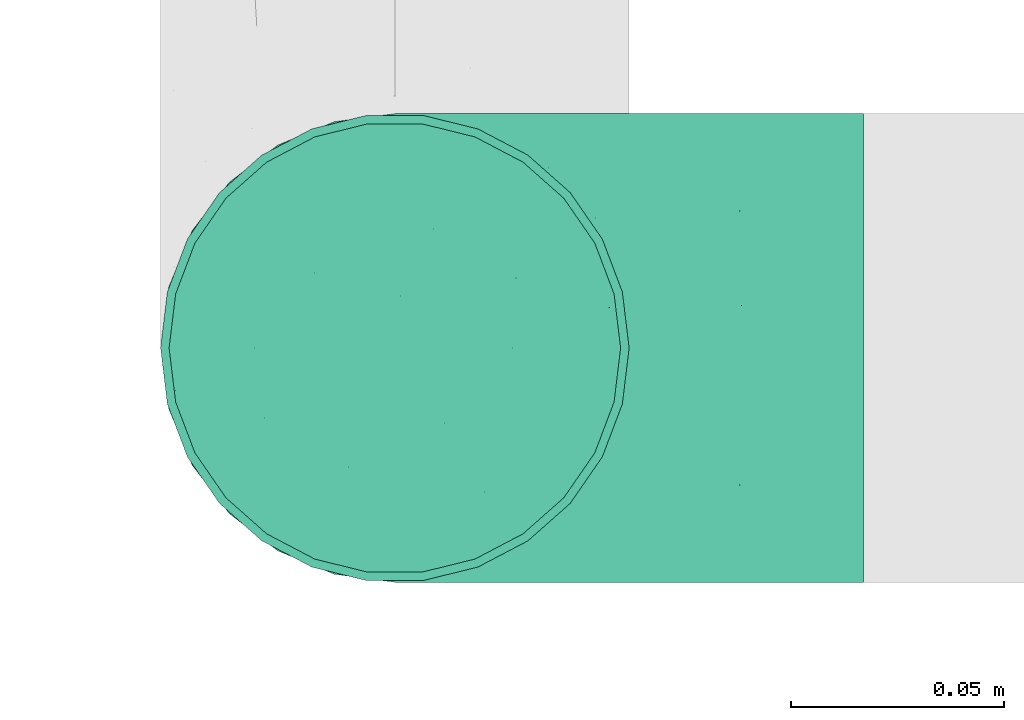
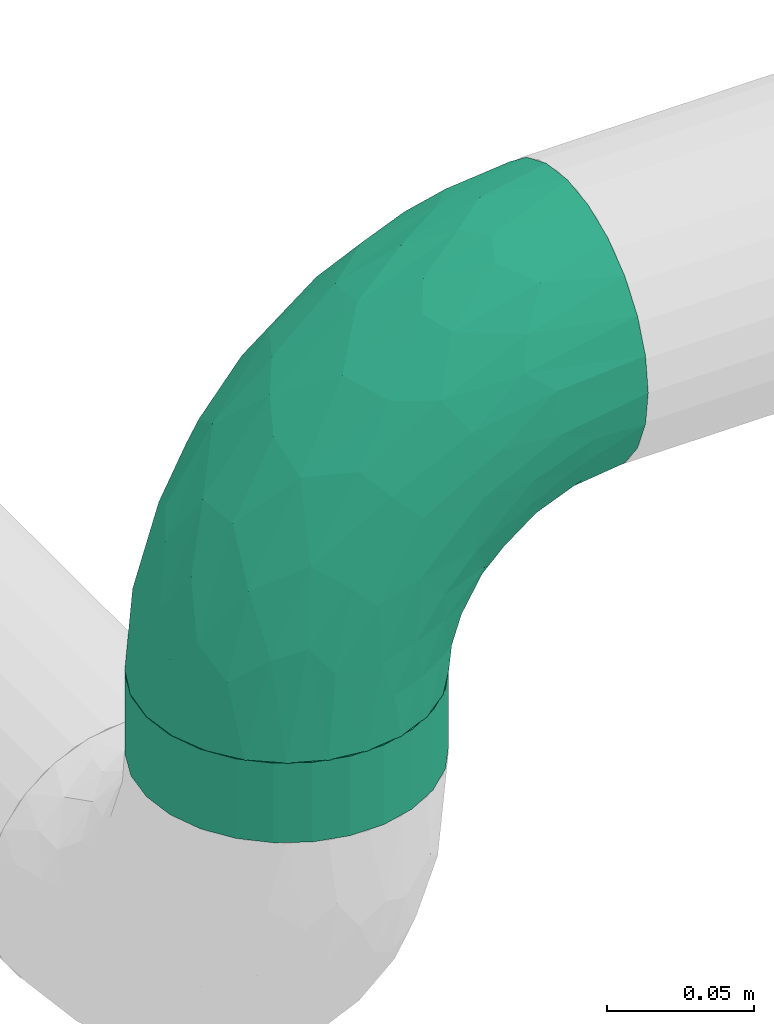
# One storey, part 37 of 91: 1 flow fitting, 1 flow segment.
"""IFC2X3 building model written with IfcOpenShell, lengths in millimetres."""

from ifc_helpers import new_model, entity, si_unit, converted_unit, derived_unit, direction, frame, origin_with_axes, origin_2d_with_axis, place, context, subcontext, project, spatial, hollow_circle, extrude, open_shell, surface_model, source, transform, mapped, material, layer, layer_set, layer_usage, type_object, element, save


model = new_model("IFC2X3")

# Units and contexts
model_context = context("Model", 3, precision=1e-05, world=origin_with_axes(), true_north=direction((0.0, 1.0)))
body_context = subcontext(model_context, "Body", "Model", "MODEL_VIEW")
ifc_project = project(units=[si_unit("AREAUNIT", "SQUARE_METRE"), si_unit("VOLUMEUNIT", "CUBIC_METRE", prefix="DECI"), si_unit("TIMEUNIT", "SECOND"), si_unit("THERMODYNAMICTEMPERATUREUNIT", "DEGREE_CELSIUS"), si_unit("PRESSUREUNIT", "PASCAL"), si_unit("MASSUNIT", "GRAM", prefix="KILO"), si_unit("LENGTHUNIT", "METRE", prefix="MILLI"), si_unit("POWERUNIT", "WATT"), si_unit("ELECTRICCURRENTUNIT", "AMPERE"), si_unit("ELECTRICVOLTAGEUNIT", "VOLT"), derived_unit("VOLUMETRICFLOWRATEUNIT", [(si_unit("VOLUMEUNIT", "CUBIC_METRE", prefix="DECI"), 1), (si_unit("TIMEUNIT", "SECOND"), -1)]), derived_unit("LINEARVELOCITYUNIT", [(si_unit("LENGTHUNIT", "METRE"), 1), (si_unit("TIMEUNIT", "SECOND"), -1)]), derived_unit("MASSDENSITYUNIT", [(si_unit("MASSUNIT", "GRAM", prefix="KILO"), 1), (si_unit("VOLUMEUNIT", "CUBIC_METRE"), -1)]), converted_unit("PLANEANGLEUNIT", "DEGREE", entity("IfcRatioMeasure", 0.01745), si_unit("PLANEANGLEUNIT", "RADIAN"), dimensions=[0, 0, 0, 0, 0, 0, 0])], contexts=[model_context])

# Site, building, storey
site_placement = place(None, origin_with_axes())
site = spatial("IfcSite", under=ifc_project, at=site_placement, CompositionType="ELEMENT")
building_placement = place(site_placement, origin_with_axes())
building = spatial("IfcBuilding", under=site, at=building_placement, Name="mc-building", CompositionType="ELEMENT")
storey_placement = place(building_placement, frame((0.0, 0.0, 8700.0), z_axis=(0.0, 0.0, 1.0), x_axis=(1.0, 0.0, 0.0)))
storey = spatial("IfcBuildingStorey", under=building, at=storey_placement, CompositionType="ELEMENT", Elevation=8700.0)

# Flow segment
ifc_material = material(Name="FZ1")
ifc_layer = layer(ifc_material, 0.0)
ifc_layer_set = layer_set([ifc_layer], Name="FZ1")
ifc_layer_usage = layer_usage(ifc_layer_set, "AXIS1", "POSITIVE", 0.0)
duct_segment_type = type_object("IfcDuctSegmentType", PredefinedType="RIGIDSEGMENT")
shared_shape_1 = source(origin_with_axes(), body_context, "Body", "SweptSolid", [
    extrude(hollow_circle(Radius=55.0, WallThickness=2.0, at=origin_2d_with_axis()), frame((0.0, 0.0, 0.0), z_axis=(1.0, 0.0, 0.0), x_axis=(0.0, 1.0, 0.0)), (0.0, 0.0, 1.0), 33.0),
])
flow_segment_placement = place(storey_placement, frame((5487.14677, 10175.43966, 558.0), z_axis=(0.0, 1.0, 0.0), x_axis=(0.0, 0.0, -1.0)))
element("IfcFlowSegment", 1, at=flow_segment_placement, inside=storey, type_object=duct_segment_type, material=ifc_layer_usage, context=body_context, shape_type="MappedRepresentation", body=[
    mapped(shared_shape_1, transform((0.0, 0.0, 0.0), scale=1.0)),
])

# Flow fitting
duct_fitting_type = type_object("IfcDuctFittingType", Name="BU", PredefinedType="BEND")
shared_shape_2 = source(origin_with_axes(), body_context, "Body", "SurfaceModel", [
    surface_model("IfcShellBasedSurfaceModel", [(-110.0, 0.0, -55.0), (-110.0, -14.23505, -53.12592), (-110.0, 14.23505, -53.12592), (-110.0, 53.12592, 14.23505), (-110.0, 27.5, -47.63139), (-110.0, 38.89087, -38.89087), (-110.0, -55.0, 0.0), (-110.0, -53.12592, 14.23505), (-110.0, -38.89087, -38.89087), (-110.0, -27.5, -47.63139), (-110.0, -53.12592, -14.23505), (-110.0, -47.63139, -27.5), (-110.0, -14.23505, 53.12592), (-110.0, 14.23505, 53.12592), (-110.0, 27.5, 47.63139), (-110.0, -47.63139, 27.5), (-110.0, -38.89087, 38.89087), (-110.0, -27.5, 47.63139), (-110.0, 0.0, 55.0), (-110.0, 55.0, 0.0), (-110.0, 53.12592, -14.23505), (-110.0, 47.63139, -27.5), (-110.0, 47.63139, 27.5), (-110.0, 38.89087, 38.89087), (-14.23505, 110.0, -53.12592), (-55.0, 110.0, 0.0), (0.0, 110.0, -55.0), (-27.5, 110.0, -47.63139), (-38.89087, 110.0, -38.89087), (-47.63139, 110.0, -27.5), (38.89087, 110.0, -38.89087), (53.12592, 110.0, 14.23505), (27.5, 110.0, -47.63139), (14.23505, 110.0, -53.12592), (47.63139, 110.0, -27.5), (53.12592, 110.0, -14.23505), (55.0, 110.0, 0.0), (-53.12592, 110.0, -14.23505), (-53.12592, 110.0, 14.23505), (-47.63139, 110.0, 27.5), (-38.89087, 110.0, 38.89087), (-27.5, 110.0, 47.63139), (0.0, 110.0, 55.0), (-14.23505, 110.0, 53.12592), (38.89087, 110.0, 38.89087), (47.63139, 110.0, 27.5), (27.5, 110.0, 47.63139), (14.23505, 110.0, 53.12592), (-64.21732, 48.68956, 43.63444), (-76.6405, 38.18013, 45.55988), (-60.44912, 32.56953, 51.94617), (-76.00813, 5.38378, 55.0), (-90.15553, 11.94394, 54.09138), (-78.5998, 26.77405, 50.81338), (-70.18771, 18.55163, 54.03432), (-75.55424, 54.2118, 32.41257), (-93.27622, 45.77614, 33.48188), (-96.12334, 22.13664, 50.81337), (-21.00813, 45.34362, 55.0), (-18.36258, 70.48427, 54.04484), (-32.04182, 59.64019, 52.24446), (-63.88653, 74.77858, 17.99134), (-74.66383, 63.08407, 19.92123), (-63.60674, 66.07878, 29.97482), (-99.597, 52.72185, 18.52927), (-93.11138, 56.59448, 10.50359), (-98.21577, 57.34403, 0.0), (-53.42855, 92.60092, 21.04759), (-88.54852, 54.8376, 21.04759), (-11.86161, 90.23965, 54.10313), (-5.38378, 76.00813, 55.0), (-57.34403, 98.21577, 0.0), (-56.64619, 93.12774, 10.22088), (-45.34362, 21.00813, 55.0), (-44.60838, 44.60838, 52.13415), (-92.68484, 35.46673, 43.63443), (-22.25266, 95.40765, 50.81337), (-35.97783, 90.61597, 43.63443), (-43.70931, 69.58671, 44.47149), (-27.23711, 77.39884, 50.81337), (-57.2828, 79.3123, 24.9774), (-58.67786, 84.31125, 16.04456), (-82.93277, 60.36161, 12.91784), (-49.88337, 54.51816, 47.224), (-74.57753, 66.83759, 9.55742), (-45.35812, 94.97281, 33.48188), (-59.18663, 88.95241, 0.0), (-51.517, 78.6292, 33.48188), (-65.14788, 80.03077, 0.0), (-56.45322, 62.06476, 39.63545), (-88.95241, 59.18663, 0.0), (-71.10913, 71.10913, 0.0), (-80.03077, 65.14788, 0.0), (-94.9309, 45.36788, -33.48188), (-93.11358, 56.60141, -10.46614), (-99.64997, 52.79499, -18.30015), (-90.20425, 36.08686, -43.63443), (-79.99933, 46.56772, -37.92748), (-76.00813, 5.38378, -55.0), (-72.75364, 19.68651, -53.60527), (-45.34362, 21.00813, -55.0), (-21.91957, 65.12078, -53.85897), (-5.38378, 76.00813, -55.0), (-21.00813, 45.34362, -55.0), (-35.41876, 92.89265, -43.63443), (-91.10309, 11.02766, -54.21832), (-45.77614, 93.27622, -33.48188), (-90.50474, 23.21022, -50.81337), (-70.92854, 33.31794, -49.51754), (-78.52933, 63.35627, -11.73997), (-24.91508, 84.05606, -50.81337), (-88.78941, 54.74452, -21.04759), (-69.59921, 57.34866, -33.48187), (-73.36422, 62.46673, -22.94182), (-63.49062, 67.59111, -28.46929), (-56.59448, 93.11138, -10.50359), (-54.8376, 88.54852, -21.04759), (-54.10679, 75.85581, -32.31867), (-57.75956, 31.09612, -52.80882), (-52.72185, 99.597, -18.52927), (-12.62913, 89.46304, -53.99097), (-34.46825, 66.46123, -50.04329), (-43.9837, 43.9837, -52.42279), (-65.78527, 72.58348, -17.68796), (-70.34468, 43.65295, -44.21951), (-57.47001, 51.99467, -44.91465), (-60.72547, 82.29174, -12.88567), (-42.34915, 74.24548, -43.63444), (-57.25194, 63.5016, -38.08211), (-80.95344, 53.56991, -29.32027), (-52.32891, 4.55257, -54.0482), (32.52942, 47.13398, -30.48571), (14.88266, 20.92917, -33.7947), (14.95561, 36.05775, -42.26543), (30.24048, 70.09027, -41.7461), (19.3559, 65.35825, -48.00507), (-70.35075, -46.44478, -19.5952), (-47.13398, -32.52942, -30.48571), (-28.49299, -30.5778, -16.4009), (-4.55257, 52.32891, -54.0482), (-22.4954, 22.4954, -53.25347), (-75.47368, -11.22546, -52.60718), (-81.32209, -51.5606, -9.98467), (-80.81763, -41.84862, -32.14655), (-70.09027, -30.24048, -41.7461), (-36.05774, -14.95561, -42.26543), (-9.15831, -10.852, -27.8997), (-65.35825, -19.3559, -48.00507), (11.22546, 75.47368, -52.60718), (3.94376, 43.9333, -50.53315), (-13.39742, 13.39743, -48.13058), (-43.9333, -3.94376, -50.53315), (49.37776, 67.29486, 0.0), (41.8609, 47.82256, -9.92641), (50.20582, 74.51695, -9.9731), (18.93131, 11.7156, -17.56239), (-27.5, -32.89419, 0.0), (-1.23348, -12.25375, -12.18106), (41.84862, 80.81763, -32.14655), (35.70604, 41.31408, -20.38235), (46.44478, 70.35075, -19.5952), (32.89419, 27.5, 0.0), (6.67262, -6.67262, 0.0), (-67.29486, -49.37776, 0.0), (-50.36265, -42.95545, -9.51562), (-5.47251, 5.47251, -39.92906), (-70.35075, -46.44478, 19.5952), (-74.51695, -50.20582, 9.9731), (-41.31407, -35.70604, 20.38235), (-47.13398, -32.52942, 30.48571), (-80.81763, -41.84862, 32.14655), (-4.55257, 52.32891, 54.0482), (11.22546, 75.47368, 52.60718), (-43.9333, -3.94376, 50.53315), (-65.35825, -19.3559, 48.00507), (-36.05774, -14.95561, 42.26543), (-70.09027, -30.24048, 41.7461), (-11.7156, -18.93131, 17.56239), (30.5778, 28.49299, 16.4009), (12.25375, 1.23348, 12.18106), (51.5606, 81.32209, 9.98467), (42.95545, 50.36265, 9.51562), (-75.47368, -11.22546, 52.60718), (-52.32891, 4.55257, 54.0482), (3.94376, 43.9333, 50.53315), (-22.4954, 22.4954, 53.25347), (-13.39742, 13.39743, 48.13058), (10.852, 9.15831, 27.8997), (-20.92916, -14.88266, 33.79469), (-47.82256, -41.8609, 9.92641), (32.52942, 47.13398, 30.48571), (46.44478, 70.35075, 19.5952), (41.84862, 80.81763, 32.14655), (30.24048, 70.09027, 41.7461), (19.3559, 65.35825, 48.00507), (14.95561, 36.05775, 42.26543), (-5.47251, 5.47251, 39.92906)], [open_shell([[[0, 1, 2]], [[2, 3, 4]], [[4, 3, 5]], [[2, 6, 7]], [[8, 6, 9]], [[1, 9, 6]], [[10, 6, 11]], [[8, 11, 6]], [[6, 2, 1]], [[12, 13, 14]], [[15, 2, 7]], [[16, 17, 2]], [[2, 17, 12]], [[12, 18, 13]], [[19, 20, 3]], [[5, 3, 21]], [[20, 21, 3]], [[22, 3, 2]], [[23, 22, 2]], [[12, 14, 2]], [[2, 14, 23]], [[15, 16, 2]], [[24, 25, 26]], [[27, 25, 24]], [[25, 28, 29]], [[28, 25, 27]], [[30, 26, 31]], [[26, 30, 32]], [[32, 33, 26]], [[34, 31, 35]], [[31, 34, 30]], [[35, 31, 36]], [[29, 37, 25]], [[38, 39, 26]], [[39, 40, 26]], [[41, 42, 40]], [[42, 26, 40]], [[42, 41, 43]], [[26, 44, 45]], [[31, 26, 45]], [[26, 46, 44]], [[47, 46, 26]], [[42, 47, 26]], [[25, 38, 26]], [[48, 49, 50]], [[18, 51, 52]], [[53, 54, 50]], [[55, 56, 49]], [[56, 22, 23]], [[13, 57, 14]], [[58, 59, 60]], [[61, 62, 63]], [[3, 64, 65]], [[53, 52, 54]], [[3, 65, 66]], [[67, 39, 38]], [[56, 68, 64]], [[65, 64, 68]], [[69, 59, 70]], [[38, 71, 72]], [[73, 58, 74]], [[75, 49, 56]], [[76, 69, 43]], [[53, 57, 52]], [[77, 78, 79]], [[41, 76, 43]], [[43, 69, 42]], [[55, 68, 56]], [[23, 14, 75]], [[76, 77, 79]], [[80, 67, 81]], [[62, 82, 68]], [[60, 78, 83]], [[62, 84, 82]], [[85, 77, 40]], [[81, 67, 72]], [[86, 72, 71]], [[87, 85, 67]], [[61, 81, 88]], [[77, 41, 40]], [[78, 77, 87]], [[23, 75, 56]], [[83, 89, 48]], [[85, 40, 39]], [[62, 68, 55]], [[89, 87, 63]], [[83, 48, 50]], [[57, 75, 14]], [[49, 75, 53]], [[67, 85, 39]], [[87, 77, 85]], [[63, 62, 55]], [[89, 55, 48]], [[80, 63, 87]], [[66, 65, 90]], [[66, 19, 3]], [[84, 91, 92]], [[92, 90, 82]], [[65, 82, 90]], [[61, 84, 62]], [[92, 82, 84]], [[68, 82, 65]], [[3, 22, 64]], [[56, 64, 22]], [[38, 25, 71]], [[81, 72, 86]], [[38, 72, 67]], [[91, 61, 88]], [[80, 81, 61]], [[63, 80, 61]], [[67, 80, 87]], [[77, 76, 41]], [[79, 59, 69]], [[79, 69, 76]], [[42, 69, 70]], [[60, 59, 79]], [[58, 70, 59]], [[78, 60, 79]], [[58, 60, 74]], [[52, 57, 13]], [[75, 57, 53]], [[18, 52, 13]], [[52, 51, 54]], [[51, 73, 54]], [[50, 73, 74]], [[73, 50, 54]], [[50, 74, 83]], [[60, 83, 74]], [[89, 83, 78]], [[87, 89, 78]], [[55, 89, 63]], [[50, 49, 53]], [[55, 49, 48]], [[81, 86, 88]], [[91, 84, 61]], [[5, 21, 93]], [[90, 94, 66]], [[20, 94, 95]], [[96, 93, 97]], [[98, 99, 100]], [[96, 4, 5]], [[101, 102, 103]], [[28, 27, 104]], [[2, 105, 0]], [[104, 106, 28]], [[99, 105, 107]], [[108, 107, 96]], [[90, 109, 94]], [[107, 2, 4]], [[20, 66, 94]], [[27, 24, 110]], [[109, 111, 94]], [[112, 113, 114]], [[37, 115, 71]], [[116, 106, 117]], [[99, 118, 100]], [[116, 115, 119]], [[37, 119, 115]], [[24, 120, 110]], [[121, 110, 101]], [[119, 106, 116]], [[101, 110, 120]], [[122, 103, 100]], [[117, 123, 116]], [[124, 125, 108]], [[115, 116, 126]], [[106, 29, 28]], [[26, 102, 120]], [[127, 104, 110]], [[97, 124, 96]], [[125, 122, 118]], [[128, 127, 125]], [[96, 5, 93]], [[115, 126, 86]], [[117, 106, 127]], [[111, 113, 129]], [[95, 93, 21]], [[97, 129, 112]], [[110, 104, 27]], [[106, 104, 127]], [[96, 107, 4]], [[99, 107, 108]], [[99, 108, 118]], [[105, 99, 98]], [[112, 114, 128]], [[121, 125, 127]], [[20, 19, 66]], [[109, 90, 92]], [[94, 111, 95]], [[91, 123, 109]], [[129, 113, 112]], [[93, 95, 111]], [[21, 20, 95]], [[71, 115, 86]], [[71, 25, 37]], [[123, 91, 88]], [[126, 116, 123]], [[123, 88, 126]], [[86, 126, 88]], [[37, 29, 119]], [[106, 119, 29]], [[129, 93, 111]], [[124, 112, 125]], [[0, 105, 98]], [[107, 105, 2]], [[125, 118, 108]], [[100, 118, 122]], [[93, 129, 97]], [[113, 111, 109]], [[109, 123, 113]], [[114, 123, 117]], [[123, 114, 113]], [[128, 114, 117]], [[127, 128, 117]], [[112, 128, 125]], [[103, 122, 101]], [[110, 121, 127]], [[101, 122, 121]], [[125, 121, 122]], [[26, 120, 24]], [[101, 120, 102]], [[96, 124, 108]], [[92, 91, 109]], [[112, 124, 97]], [[100, 130, 98]], [[131, 132, 133]], [[32, 134, 135]], [[136, 137, 138]], [[139, 140, 103]], [[98, 141, 0]], [[142, 10, 136]], [[143, 144, 137]], [[6, 10, 142]], [[137, 145, 146]], [[144, 147, 145]], [[143, 136, 11]], [[11, 136, 10]], [[8, 143, 11]], [[148, 149, 139]], [[8, 9, 144]], [[9, 1, 147]], [[130, 141, 98]], [[103, 140, 100]], [[148, 135, 149]], [[150, 151, 140]], [[152, 153, 154]], [[130, 140, 151]], [[148, 26, 33]], [[147, 1, 141]], [[155, 146, 132]], [[156, 138, 157]], [[134, 30, 158]], [[150, 140, 149]], [[158, 30, 34]], [[30, 134, 32]], [[153, 159, 160]], [[131, 160, 159]], [[144, 145, 137]], [[36, 152, 154]], [[146, 138, 137]], [[155, 161, 162]], [[158, 160, 131]], [[133, 149, 135]], [[156, 163, 164]], [[163, 142, 164]], [[139, 103, 102]], [[153, 152, 161]], [[34, 35, 160]], [[162, 157, 155]], [[132, 165, 133]], [[157, 146, 155]], [[140, 130, 100]], [[141, 130, 151]], [[141, 151, 147]], [[141, 1, 0]], [[102, 26, 148]], [[140, 139, 149]], [[102, 148, 139]], [[135, 33, 32]], [[151, 150, 145]], [[9, 147, 144]], [[151, 145, 147]], [[145, 165, 146]], [[135, 148, 33]], [[133, 135, 134]], [[131, 133, 134]], [[133, 165, 150]], [[133, 150, 149]], [[145, 150, 165]], [[132, 131, 159]], [[146, 165, 132]], [[160, 158, 34]], [[134, 158, 131]], [[144, 143, 8]], [[136, 143, 137]], [[155, 153, 161]], [[154, 153, 160]], [[153, 155, 159]], [[132, 159, 155]], [[160, 35, 154]], [[36, 154, 35]], [[164, 136, 138]], [[6, 142, 163]], [[136, 164, 142]], [[156, 164, 138]], [[156, 157, 162]], [[146, 157, 138]], [[15, 7, 166]], [[6, 163, 167]], [[168, 169, 166]], [[166, 169, 170]], [[171, 172, 70]], [[173, 174, 175]], [[17, 176, 174]], [[177, 156, 162]], [[176, 16, 170]], [[170, 16, 15]], [[161, 178, 179]], [[152, 180, 181]], [[182, 173, 183]], [[18, 12, 182]], [[184, 185, 186]], [[183, 185, 73]], [[183, 73, 51]], [[177, 187, 188]], [[189, 168, 166]], [[187, 178, 190]], [[16, 176, 17]], [[161, 152, 181]], [[45, 191, 31]], [[45, 44, 192]], [[192, 191, 45]], [[180, 36, 31]], [[193, 194, 195]], [[46, 47, 194]], [[193, 195, 190]], [[193, 44, 46]], [[172, 42, 70]], [[185, 58, 73]], [[189, 163, 156]], [[163, 189, 167]], [[70, 58, 171]], [[184, 171, 185]], [[169, 188, 175]], [[180, 31, 191]], [[192, 193, 190]], [[191, 190, 178]], [[182, 174, 173]], [[194, 47, 172]], [[190, 195, 187]], [[186, 185, 173]], [[162, 179, 177]], [[188, 196, 175]], [[179, 187, 177]], [[185, 171, 58]], [[172, 171, 184]], [[172, 184, 194]], [[172, 47, 42]], [[51, 18, 182]], [[185, 183, 173]], [[51, 182, 183]], [[174, 12, 17]], [[184, 186, 195]], [[46, 194, 193]], [[184, 195, 194]], [[195, 196, 187]], [[174, 182, 12]], [[175, 174, 176]], [[169, 175, 176]], [[175, 196, 186]], [[175, 186, 173]], [[195, 186, 196]], [[188, 169, 168]], [[187, 196, 188]], [[166, 170, 15]], [[176, 170, 169]], [[193, 192, 44]], [[191, 192, 190]], [[177, 189, 156]], [[167, 189, 166]], [[189, 177, 168]], [[188, 168, 177]], [[166, 7, 167]], [[6, 167, 7]], [[181, 191, 178]], [[36, 180, 152]], [[191, 181, 180]], [[161, 181, 178]], [[161, 179, 162]], [[187, 179, 178]]])]),
])
flow_fitting_placement = place(storey_placement, frame((5487.14677, 10175.43966, 668.0), z_axis=(0.0, 1.0, 0.0), x_axis=(0.0, 0.0, 1.0)))
element("IfcFlowFitting", 2, at=flow_fitting_placement, inside=storey, type_object=duct_fitting_type, Name="BU", context=body_context, shape_type="MappedRepresentation", body=[
    mapped(shared_shape_2, transform((0.0, 0.0, 0.0), scale=1.0)),
])

save(model, "model.ifc")
